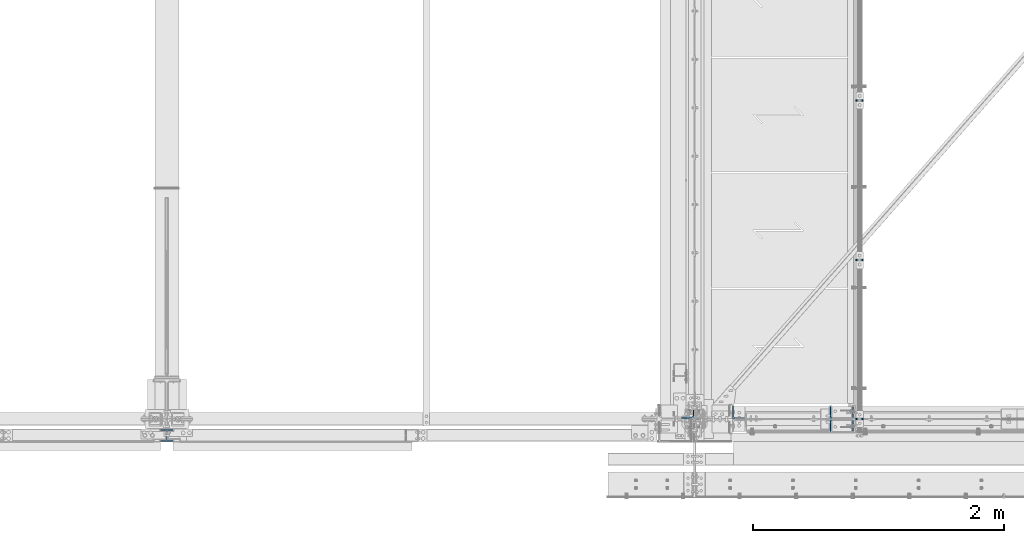
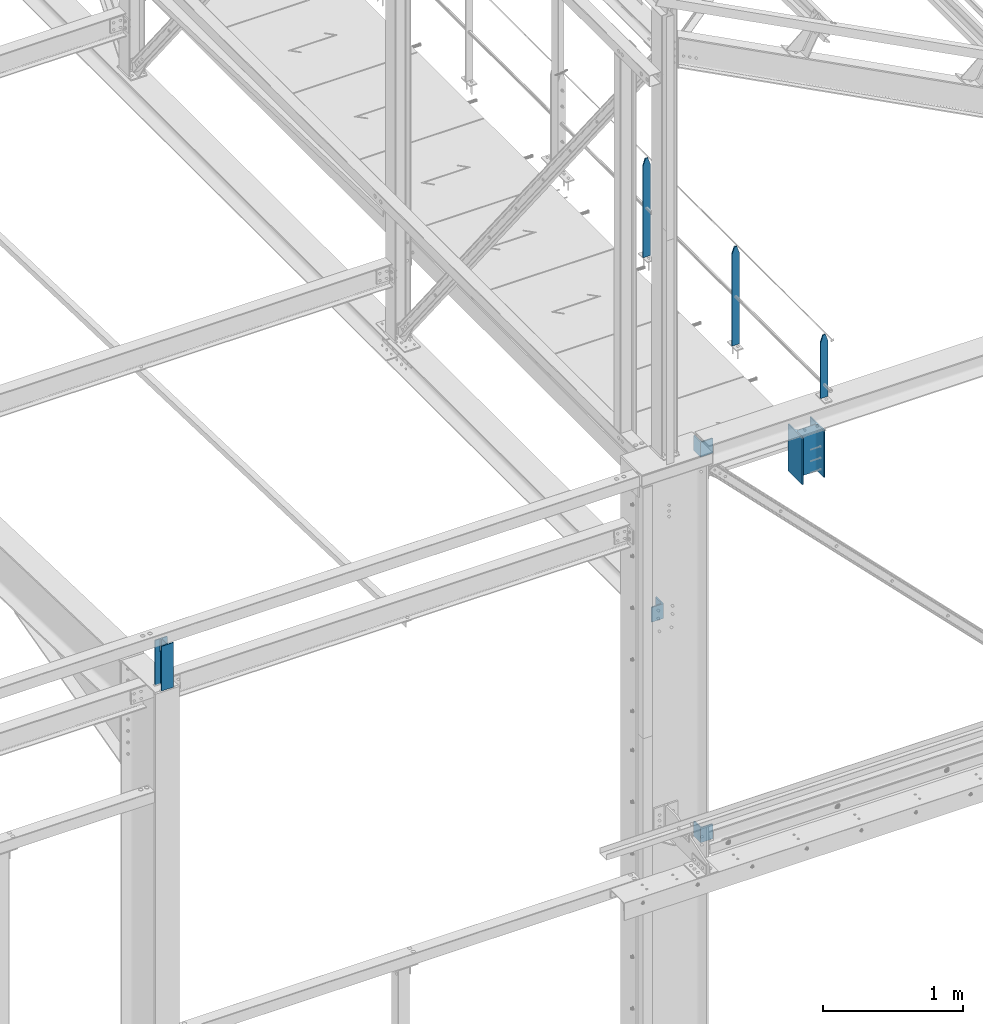
# One storey, part 21 of 496: 8 columns, 6 elements without a shape of their own.
"""IFC2X3 building model written with IfcOpenShell, lengths in millimetres."""

from ifc_helpers import new_model, si_unit, frame, origin_with_axes, origin_2d_with_axis, place, context, subcontext, project, spatial, rectangle, i_section, l_section, extrude, clip, halfspace, material, type_object, element, aggregate, save


model = new_model("IFC2X3")

# Units and contexts
model_context = context("Model", 3, precision=1e-05, world=origin_with_axes())
body_context = subcontext(model_context, "Body", "Model", "MODEL_VIEW")
ifc_project = project(units=[si_unit("LENGTHUNIT", "METRE", prefix="MILLI"), si_unit("AREAUNIT", "SQUARE_METRE"), si_unit("VOLUMEUNIT", "CUBIC_METRE"), si_unit("MASSUNIT", "GRAM", prefix="KILO"), si_unit("TIMEUNIT", "SECOND"), si_unit("PLANEANGLEUNIT", "RADIAN"), si_unit("SOLIDANGLEUNIT", "STERADIAN"), si_unit("THERMODYNAMICTEMPERATUREUNIT", "DEGREE_CELSIUS"), si_unit("LUMINOUSINTENSITYUNIT", "LUMEN")], contexts=[model_context])

# Site, building, storey
site_placement = place(None, origin_with_axes())
site = spatial("IfcSite", under=ifc_project, at=site_placement, CompositionType="ELEMENT")
building_placement = place(site_placement, origin_with_axes())
building = spatial("IfcBuilding", under=site, at=building_placement, Name="Undefined", CompositionType="ELEMENT")
storey_placement = place(building_placement, origin_with_axes())
storey = spatial("IfcBuildingStorey", under=building, at=storey_placement, Name="Undefined", CompositionType="ELEMENT", Elevation=0.0)

# Assembly, columns
assembly_1_placement = place(storey_placement, origin_with_axes())
assembly_1 = element("IfcElementAssembly", 1, at=assembly_1_placement, inside=storey, Name="MAIN COURANTE", AssemblyPlace="NOTDEFINED", PredefinedType="NOTDEFINED")
ifc_material_1 = material(Name="Undefined/S235-E24")
column_type_1 = type_object("IfcColumnType", PredefinedType="NOTDEFINED")
column_1_placement = place(assembly_1_placement, frame((13993.9998835557, 0.0, 8560.00000822896), z_axis=(0.0, 0.0, 1.0), x_axis=(1.0, 0.0, 0.0)))
column_1 = element("IfcColumn", 2, at=column_1_placement, type_object=column_type_1, material=ifc_material_1, Name="MONTANT", context=body_context, shape_type="Clipping", body=[
    clip(clip(extrude(rectangle(XDim=10.0, YDim=60.0, at=origin_2d_with_axis()), frame((0.0, 0.0, 547.599997130677), z_axis=(0.0, 0.0, -1.0), x_axis=(0.0, 1.0, 0.0)), (0.0, 0.0, 1.0), 547.6), halfspace(frame((30.0000001607259, -4.99999971485146, 487.599997170884), z_axis=(0.948683298050514, 0.0, 0.316227766016838), x_axis=(-0.316227766016838, 0.0, 0.948683298050514)), False)), halfspace(frame((-29.9999998292697, 5.00000034506605, 487.599997177174), z_axis=(-0.948683298050514, 0.0, 0.316227766016838), x_axis=(0.316227766016838, 0.0, 0.948683298050514)), False)),
])
column_2_placement = place(assembly_1_placement, frame((13993.9998835557, 1265.00344717076, 8250.00000822896), z_axis=(0.0, 0.0, 1.0), x_axis=(1.0, 0.0, 0.0)))
column_2 = element("IfcColumn", 3, at=column_2_placement, type_object=column_type_1, material=ifc_material_1, Name="MONTANT", context=body_context, shape_type="Clipping", body=[
    clip(clip(extrude(rectangle(XDim=10.0, YDim=60.0, at=origin_2d_with_axis()), frame((0.0, 0.0, 857.599997130677), z_axis=(0.0, 0.0, -1.0), x_axis=(0.0, 1.0, 0.0)), (0.0, 0.0, 1.0), 857.6), halfspace(frame((30.0000001657245, -5.000000004674, 797.599997170884), z_axis=(0.948683298050514, 0.0, 0.316227766016838), x_axis=(-0.316227766016838, 0.0, 0.948683298050514)), False)), halfspace(frame((-29.9999998342682, 4.99999999524351, 797.599997177174), z_axis=(-0.948683298050514, 0.0, 0.316227766016838), x_axis=(0.316227766016838, 0.0, 0.948683298050514)), False)),
])
column_3_placement = place(assembly_1_placement, frame((13993.9998846109, 2535.00344717076, 8250.00000735839), z_axis=(0.0, 0.0, 1.0), x_axis=(1.0, 0.0, 0.0)))
column_3 = element("IfcColumn", 4, at=column_3_placement, type_object=column_type_1, material=ifc_material_1, Name="MONTANT", context=body_context, shape_type="Clipping", body=[
    clip(clip(extrude(rectangle(XDim=10.0, YDim=60.0, at=origin_2d_with_axis()), frame((0.0, 0.0, 857.599997130677), z_axis=(0.0, 0.0, -1.0), x_axis=(0.0, 1.0, 0.0)), (0.0, 0.0, 1.0), 857.6), halfspace(frame((30.0000001657245, -5.000000004674, 797.599997170884), z_axis=(0.948683298050514, 0.0, 0.316227766016838), x_axis=(-0.316227766016838, 0.0, 0.948683298050514)), False)), halfspace(frame((-29.9999998342682, 4.99999999524351, 797.599997177174), z_axis=(-0.948683298050514, 0.0, 0.316227766016838), x_axis=(0.316227766016838, 0.0, 0.948683298050514)), False)),
])
aggregate(assembly_1, [column_1, column_2, column_3])

# Assembly, column
assembly_2_placement = place(storey_placement, origin_with_axes())
assembly_2 = element("IfcElementAssembly", 5, at=assembly_2_placement, inside=storey, AssemblyPlace="NOTDEFINED", PredefinedType="NOTDEFINED")
column_type_2 = type_object("IfcColumnType", PredefinedType="NOTDEFINED")
column_4_placement = place(assembly_2_placement, frame((12626.4999999846, 56.0022948285226, 7089.99987296172), z_axis=(0.0, 0.0, 1.0), x_axis=(0.0, 1.0, 0.0)))
column_4 = element("IfcColumn", 6, at=column_4_placement, type_object=column_type_2, material=ifc_material_1, context=body_context, shape_type="SweptSolid", body=[
    extrude(l_section(Depth=100.0, Width=100.0, Thickness=10.0, FilletRadius=12.0, EdgeRadius=6.0, at=origin_2d_with_axis()), frame((0.0, 1.81898940354586e-12, 129.999999999999), z_axis=(0.0, 0.0, -1.0), x_axis=(0.0, 1.0, 0.0)), (0.0, 0.0, 1.0), 130.0),
])
aggregate(assembly_2, [column_4])

assembly_3_placement = place(storey_placement, origin_with_axes())
assembly_3 = element("IfcElementAssembly", 7, at=assembly_3_placement, inside=storey, AssemblyPlace="NOTDEFINED", PredefinedType="NOTDEFINED")
column_5_placement = place(assembly_3_placement, frame((13029.997437269, 53.500000000834, 8390.00002208745), z_axis=(0.0, 0.0, 1.0), x_axis=(1.0, 0.0, 0.0)))
column_5 = element("IfcColumn", 8, at=column_5_placement, type_object=column_type_2, material=ifc_material_1, context=body_context, shape_type="SweptSolid", body=[
    extrude(l_section(Depth=100.0, Width=100.0, Thickness=10.0, FilletRadius=12.0, EdgeRadius=6.0, at=origin_2d_with_axis()), frame((0.0, 1.81898940354586e-12, 129.999999999999), z_axis=(0.0, 0.0, -1.0), x_axis=(0.0, 1.0, 0.0)), (0.0, 0.0, 1.0), 130.0),
])
aggregate(assembly_3, [column_5])

assembly_4_placement = place(storey_placement, origin_with_axes())
assembly_4 = element("IfcElementAssembly", 9, at=assembly_4_placement, inside=storey, AssemblyPlace="NOTDEFINED", PredefinedType="NOTDEFINED")
column_6_placement = place(assembly_4_placement, frame((13029.997437269, 53.500000000834, 5030.00085394835), z_axis=(0.0, 0.0, 1.0), x_axis=(1.0, 0.0, 0.0)))
column_6 = element("IfcColumn", 10, at=column_6_placement, type_object=column_type_2, material=ifc_material_1, context=body_context, shape_type="SweptSolid", body=[
    extrude(l_section(Depth=100.0, Width=100.0, Thickness=10.0, FilletRadius=12.0, EdgeRadius=6.0, at=origin_2d_with_axis()), frame((0.0, 1.81898940354586e-12, 129.999999999999), z_axis=(0.0, 0.0, -1.0), x_axis=(0.0, 1.0, 0.0)), (0.0, 0.0, 1.0), 130.0),
])
aggregate(assembly_4, [column_6])

assembly_5_placement = place(storey_placement, origin_with_axes())
assembly_5 = element("IfcElementAssembly", 11, at=assembly_5_placement, inside=storey, Name="POTEAU", AssemblyPlace="NOTDEFINED", PredefinedType="NOTDEFINED")
ifc_material_2 = material(Name="Undefined/S275-E28")
column_type_3 = type_object("IfcColumnType", Name="HEA100", PredefinedType="NOTDEFINED")
column_7_placement = place(assembly_5_placement, frame((8480.0, -132.0, 8049.99544952393), z_axis=(0.0, 0.0, 1.0), x_axis=(0.0, 1.0, 0.0)))
column_7 = element("IfcColumn", 12, at=column_7_placement, type_object=column_type_3, material=ifc_material_2, ObjectType="HEA100", context=body_context, shape_type="Clipping", body=[
    clip(extrude(i_section(OverallWidth=100.0, OverallDepth=96.0, WebThickness=5.0, FlangeThickness=8.0, FilletRadius=12.0, at=origin_2d_with_axis()), frame((0.0, 0.0, 395.004550476075), z_axis=(0.0, 0.0, -1.0), x_axis=(0.0, 1.0, 0.0)), (0.0, 0.0, 1.0), 392.38), halfspace(frame((55.2953255032645, 0.0, 2.41509197698997), z_axis=(-0.0314107590115443, 0.0, -0.999506560367824), x_axis=(0.0, 1.0, 0.0)), False)),
])
aggregate(assembly_5, [column_7])

assembly_6_placement = place(storey_placement, origin_with_axes())
assembly_6 = element("IfcElementAssembly", 13, at=assembly_6_placement, inside=storey, Name="MONTANT", AssemblyPlace="NOTDEFINED", PredefinedType="NOTDEFINED")
column_type_4 = type_object("IfcColumnType", Name="HEA200", PredefinedType="NOTDEFINED")
column_8_placement = place(assembly_6_placement, frame((13851.4998857983, 0.0, 7940.0), z_axis=(0.0, 0.0, 1.0), x_axis=(-1.0, 0.0, 0.0)))
column_8 = element("IfcColumn", 14, at=column_8_placement, type_object=column_type_4, material=ifc_material_2, Name="MONTANT", ObjectType="HEA200", context=body_context, shape_type="SweptSolid", body=[
    extrude(i_section(OverallWidth=200.0, OverallDepth=190.0, WebThickness=6.5, FlangeThickness=10.0, FilletRadius=18.0, at=origin_2d_with_axis()), frame((0.0, 0.0, 409.995254081661), z_axis=(0.0, 0.0, -1.0), x_axis=(0.0, 1.0, 0.0)), (0.0, 0.0, 1.0), 410.0),
])
aggregate(assembly_6, [column_8])

save(model, "model.ifc")
